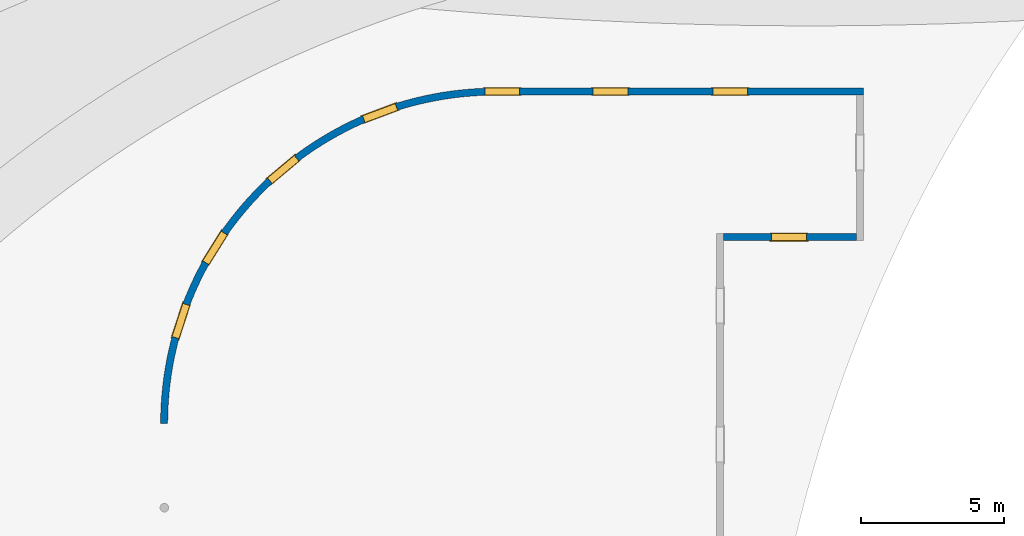
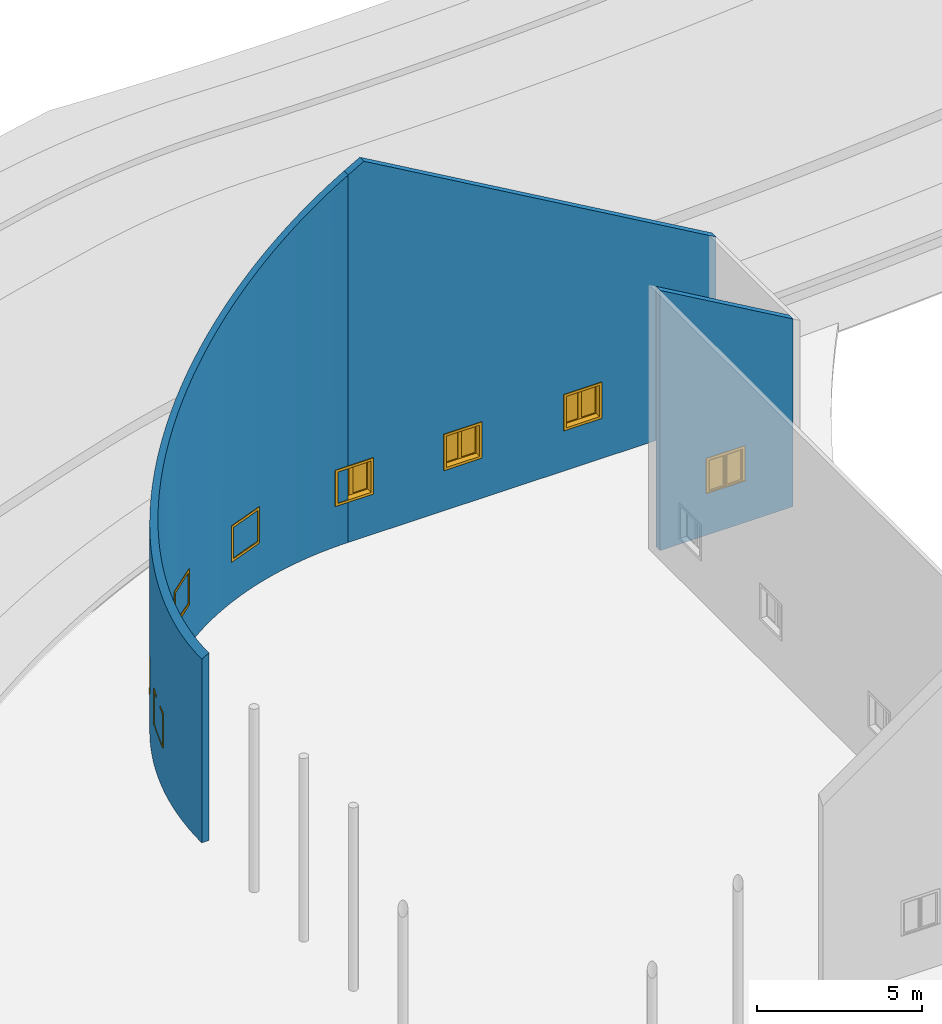
# One storey, part 10 of 39: 8 windows, 3 walls, 8 openings.
"""IFC2X3 building model written with IfcOpenShell, lengths in millimetres."""

from ifc_helpers import new_model, entity, si_unit, converted_unit, derived_unit, direction, frame, frame_2d, origin, origin_2d_with_axis, place, context, subcontext, project, spatial, polyline, circle_curve, parameter, trimmed, segment, composite_curve, rectangle, outline, extrude, clip, bounded_halfspace, source, transform, mapped, material, material_list, layer, layer_set, layer_usage, type_object, type_shapes, element, fill, save


model = new_model("IFC2X3")

# Units and contexts
model_context = context("Model", 3, precision=1e-06, world=origin(), true_north=direction((2.0, 6.12303176911189e-17, 1.0)))
context_of_model = context(None, 3, precision=1e-06, world=origin(), true_north=direction((2.0, 6.12303176911189e-17, 1.0)))
body_context = subcontext(model_context, "Body", "Model", "MODEL_VIEW")
ifc_project = project(units=[si_unit("LENGTHUNIT", "METRE", prefix="MILLI"), si_unit("AREAUNIT", "SQUARE_METRE", prefix="MILLI"), si_unit("VOLUMEUNIT", "CUBIC_METRE", prefix="MILLI"), converted_unit("PLANEANGLEUNIT", "DEGREE", entity("IfcRatioMeasure", 0.0174532925199433), si_unit("PLANEANGLEUNIT", "RADIAN"), dimensions=[0, 0, 0, 0, 0, 0, 0]), si_unit("MASSUNIT", "GRAM", prefix="KILO"), si_unit("TIMEUNIT", "SECOND"), si_unit("THERMODYNAMICTEMPERATUREUNIT", "KELVIN"), derived_unit("THERMALTRANSMITTANCEUNIT", [(si_unit("MASSUNIT", "GRAM", prefix="KILO"), 1), (si_unit("THERMODYNAMICTEMPERATUREUNIT", "KELVIN"), -1), (si_unit("TIMEUNIT", "SECOND"), -3)]), derived_unit("VOLUMETRICFLOWRATEUNIT", [(si_unit("LENGTHUNIT", "METRE"), 3), (si_unit("TIMEUNIT", "SECOND"), -1)])], contexts=[model_context, context_of_model])

# Site, building, storey
site_placement = place(None, origin())
site = spatial("IfcSite", under=ifc_project, at=site_placement, CompositionType="ELEMENT")
building_placement = place(site_placement, origin())
building = spatial("IfcBuilding", under=site, at=building_placement, CompositionType="ELEMENT")
storey_placement = place(building_placement, frame((0.0, 0.0, 4000.0)))
storey = spatial("IfcBuildingStorey", under=building, at=storey_placement, Name="Level 2", CompositionType="ELEMENT", Elevation=4000.0)

# Wall, openings, windows
ifc_material_1 = material(Name="Concrete - Cast In Situ")
ifc_layer = layer(ifc_material_1, 250.0)
ifc_layer_set = layer_set([ifc_layer], Name="Basic Wall:Structure wall")
ifc_layer_usage_1 = layer_usage(ifc_layer_set, "AXIS2", "NEGATIVE", 125.0)
wall_type = type_object("IfcWallType", Name="Basic Wall:Structure wall", PredefinedType="STANDARD", material=ifc_layer_set)
wall_1_placement = place(storey_placement, frame((-312721.196209224, 252902.530060918, 362.0), z_axis=(0.0, 0.0, 1.0), x_axis=(-1.0, 0.0, 0.0)))
wall_1 = element("IfcWallStandardCase", 1, at=wall_1_placement, inside=storey, type_object=wall_type, material=ifc_layer_usage_1, Name="Basic Wall:Structure wall", ObjectType="Basic Wall:Structure wall", context=body_context, shape_type="Clipping", body=[
    clip(clip(extrude(rectangle(XDim=12850.0000000001, YDim=249.999999999978, at=frame_2d((6425.00000000005, -3.33955085807247e-13), x_axis=(-1.0, 0.0))), origin(), (0.0, 0.0, 1.0), 13883.745878329), bounded_halfspace(frame((0.0, 125.0, 6782.33756729738), z_axis=(-0.499999999999959, 0.0, 0.866025403784462), x_axis=(0.0, -1.0, 0.0)), False, frame((0.0, 125.0, 6782.33756729738)), polyline([(0.0, 0.0), (0.0, -250.0), (12300.0, -250.0), (12300.0, 0.0), (250.0, 0.0), (0.0, 0.0)]))), bounded_halfspace(frame((12850.0, -125.0, 13566.2032302747), z_axis=(0.499999999999959, 0.0, 0.866025403784462), x_axis=(0.0, 1.0, 0.0)), False, frame((12850.0, -125.0, 13566.2032302747)), polyline([(0.0, 0.0), (0.0, 250.0), (-550.0, 250.0), (-550.0, 0.0), (0.0, 0.0)]))),
])
opening_1_placement = place(wall_1_placement, frame((13250.0, 125.0, 1553.0)))
opening_1 = element("IfcOpeningElement", 2, at=opening_1_placement, cuts=wall_1, Name="M_Casement Dbl with Trim:1220 x 1220mm:1220 x 1220mm:1", ObjectType="Opening", context=body_context, shape_type="SweptSolid", body=[
    extrude(rectangle(XDim=1220.0, YDim=1220.0, at=frame_2d((610.0, 610.0), x_axis=(-1.0, 0.0))), frame((0.0, 0.0, 0.0), z_axis=(0.0, -1.0, 0.0), x_axis=(0.0, 0.0, 1.0)), (0.0, 0.0, 1.0), 250.0),
])
opening_2_placement = place(wall_1_placement, frame((9460.05000000016, 125.0, 1553.0)))
opening_2 = element("IfcOpeningElement", 3, at=opening_2_placement, cuts=wall_1, Name="M_Casement Dbl with Trim:1220 x 1220mm:1220 x 1220mm:1", ObjectType="Opening", context=body_context, shape_type="SweptSolid", body=[
    extrude(rectangle(XDim=1220.0, YDim=1220.0, at=frame_2d((610.0, 610.0), x_axis=(-1.0, 0.0))), frame((0.0, 0.0, 0.0), z_axis=(0.0, -1.0, 0.0), x_axis=(0.0, 0.0, 1.0)), (0.0, 0.0, 1.0), 250.0),
])
opening_3_placement = place(wall_1_placement, frame((5270.1000000002, 125.0, 1553.0)))
opening_3 = element("IfcOpeningElement", 4, at=opening_3_placement, cuts=wall_1, Name="M_Casement Dbl with Trim:1220 x 1220mm:1220 x 1220mm:1", ObjectType="Opening", context=body_context, shape_type="SweptSolid", body=[
    extrude(rectangle(XDim=1220.0, YDim=1220.0, at=frame_2d((610.0, 610.0), x_axis=(-1.0, 0.0))), frame((0.0, 0.0, 0.0), z_axis=(0.0, -1.0, 0.0), x_axis=(0.0, 0.0, 1.0)), (0.0, 0.0, 1.0), 250.0),
])
ifc_material_2 = material(Name="Glass")
ifc_material_3 = material(Name="Sash")
ifc_material_4 = material(Name="Trim")
ifc_material_list_1 = material_list([ifc_material_2, ifc_material_3, ifc_material_4])
ifc_material_list_2 = material_list([ifc_material_2, ifc_material_3, ifc_material_4])
window_style_1 = type_object("IfcWindowStyle", Name="1220 x 1220mm", ConstructionType="NOTDEFINED", OperationType="NOTDEFINED", ParameterTakesPrecedence=False, Sizeable=False, material=ifc_material_list_2)
shared_shape_1 = source(origin(), body_context, "Body", "SweptSolid", [
    extrude(rectangle(XDim=482.999999999998, YDim=12.7, at=frame_2d((0.0, -1.68753899743024e-14), x_axis=(1.0, 0.0))), frame((305.0, 246.875, 63.5000000000002), z_axis=(0.0, 0.0, 1.0), x_axis=(-1.0, 0.0, 0.0)), (0.0, 0.0, 1.0), 1093.0),
    extrude(outline(polyline([(-285.949999999999, -590.950000000002), (285.949999999999, -590.950000000002), (285.949999999999, 590.950000000003), (-285.949999999999, 590.950000000003), (-285.949999999999, -590.950000000002)]), holes=[polyline([(-241.499999999998, -546.500000000003), (-241.499999999998, 546.500000000002), (241.5, 546.500000000002), (241.5, -546.500000000003), (-241.499999999998, -546.500000000003)])]), frame((305.0, 269.1, 610.0), z_axis=(0.0, -1.0, 0.0), x_axis=(-1.0, 0.0, 0.0)), (0.0, 0.0, 1.0), 44.45),
    extrude(rectangle(XDim=1359.89999999999, YDim=25.7, at=frame_2d((0.0, -1.68753899743024e-14), x_axis=(1.0, 0.0))), frame((610.0, 300.95, 0.0), z_axis=(0.0, 0.0, 1.0), x_axis=(-1.0, 0.0, 0.0)), (0.0, 0.0, 1.0), 19.0500000000014),
    extrude(outline(polyline([(-568.700000000007, 590.949999999995), (613.200000000007, 590.949999999995), (613.200000000007, 679.949999999994), (-657.700000000005, 679.949999999994), (-657.700000000005, -679.949999999993), (613.200000000006, -679.949999999993), (613.200000000006, -590.949999999995), (-568.700000000007, -590.949999999995), (-568.700000000007, 590.949999999995)])), frame((610.0, 301.1, 632.250000000007), z_axis=(0.0, -1.0, 0.0), x_axis=(0.0, 0.0, -1.0)), (0.0, 0.0, 1.0), 13.0),
    extrude(outline(polyline([(-667.25000000001, -667.249999999998), (667.25000000001, -667.249999999998), (667.25000000001, 667.249999999998), (-667.25000000001, 667.249999999998), (-667.25000000001, -667.249999999998)]), holes=[polyline([(-578.250000000011, -578.250000000001), (-578.250000000011, 578.249999999997), (578.24999999999, 578.249999999997), (578.24999999999, -578.250000000001), (-578.250000000011, -578.250000000001)])]), frame((610.0, 38.1, 610.0), z_axis=(0.0, -1.0, 0.0), x_axis=(0.0, 0.0, -1.0)), (0.0, 0.0, 1.0), 19.0),
    extrude(rectangle(XDim=482.999999999998, YDim=12.7, at=frame_2d((4.2632564145606e-14, 0.0), x_axis=(1.0, 0.0))), frame((915.0, 246.875, 63.4999999999994)), (0.0, 0.0, 1.0), 1093.0),
    extrude(outline(polyline([(-285.949999999999, -590.950000000002), (285.949999999999, -590.950000000002), (285.949999999999, 590.950000000002), (-285.949999999999, 590.950000000002), (-285.949999999999, -590.950000000002)]), holes=[polyline([(-241.499999999999, -546.500000000003), (-241.499999999999, 546.500000000001), (241.499999999999, 546.500000000001), (241.499999999999, -546.500000000003), (-241.499999999999, -546.500000000003)])]), frame((915.0, 269.1, 610.0), z_axis=(0.0, -1.0, 0.0), x_axis=(-1.0, 0.0, 0.0)), (0.0, 0.0, 1.0), 44.45),
    extrude(outline(polyline([(-610.0, -610.0), (610.0, -610.0), (610.0, 610.0), (-610.0, 610.0), (-610.0, -610.0)]), holes=[polyline([(-578.25, -578.250000000001), (-578.25, 578.25), (578.249999999997, 578.25), (578.249999999997, -578.250000000001), (-578.25, -578.250000000001)])]), frame((610.0, 224.65, 610.0), z_axis=(0.0, -1.0, 0.0), x_axis=(-1.0, 0.0, 0.0)), (0.0, 0.0, 1.0), 186.55),
    extrude(outline(polyline([(-610.0, -610.0), (610.0, -610.0), (610.0, 610.0), (-610.0, 610.0), (-610.0, -610.0)]), holes=[polyline([(-590.950000000002, -590.949999999996), (-590.950000000002, 590.95), (590.950000000003, 590.95), (590.950000000003, -590.949999999996), (-590.950000000002, -590.949999999996)])]), frame((610.0, 288.1, 610.0), z_axis=(0.0, -1.0, 0.0), x_axis=(0.0, 0.0, -1.0)), (0.0, 0.0, 1.0), 63.45),
    extrude(rectangle(XDim=38.0999999999998, YDim=63.5, at=frame_2d((0.0, -8.88178419700125e-15), x_axis=(1.0, 0.0))), frame((610.0, 256.4, 19.0499999999995)), (0.0, 0.0, 1.0), 1181.90000000001),
])
type_shapes(window_style_1, [shared_shape_1])
window_1_placement = place(opening_1_placement, frame((0.0, 38.0999999999476, 0.0), z_axis=(0.0, 0.0, 1.0), x_axis=(-1.0, 0.0, 0.0)))
window_1 = element("IfcWindow", 5, at=window_1_placement, inside=storey, type_object=window_style_1, material=ifc_material_list_1, Name="M_Casement Dbl with Trim:1220 x 1220mm", ObjectType="1220 x 1220mm", OverallHeight=1220.0, OverallWidth=1220.0, context=body_context, shape_type="MappedRepresentation", body=[
    mapped(shared_shape_1, transform((0.0, 0.0, 0.0), scale=1.0)),
])
fill(opening_1, window_1)
ifc_material_list_3 = material_list([ifc_material_2, ifc_material_3, ifc_material_4])
window_2_placement = place(opening_2_placement, frame((0.0, 38.0999999999476, 0.0), z_axis=(0.0, 0.0, 1.0), x_axis=(-1.0, 0.0, 0.0)))
window_2 = element("IfcWindow", 6, at=window_2_placement, inside=storey, type_object=window_style_1, material=ifc_material_list_3, Name="M_Casement Dbl with Trim:1220 x 1220mm", ObjectType="1220 x 1220mm", OverallHeight=1220.0, OverallWidth=1220.0, context=body_context, shape_type="MappedRepresentation", body=[
    mapped(shared_shape_1, transform((0.0, 0.0, 0.0), scale=1.0)),
])
fill(opening_2, window_2)
ifc_material_list_4 = material_list([ifc_material_2, ifc_material_3, ifc_material_4])
window_3_placement = place(opening_3_placement, frame((0.0, 38.0999999999767, 0.0), z_axis=(0.0, 0.0, 1.0), x_axis=(-1.0, 0.0, 0.0)))
window_3 = element("IfcWindow", 7, at=window_3_placement, inside=storey, type_object=window_style_1, material=ifc_material_list_4, Name="M_Casement Dbl with Trim:1220 x 1220mm", ObjectType="1220 x 1220mm", OverallHeight=1220.0, OverallWidth=1220.0, context=body_context, shape_type="MappedRepresentation", body=[
    mapped(shared_shape_1, transform((0.0, 0.0, 0.0), scale=1.0)),
])
fill(opening_3, window_3)

ifc_layer_usage_2 = layer_usage(ifc_layer_set, "AXIS2", "NEGATIVE", 125.0)
wall_2_placement = place(storey_placement, frame((-325571.196209225, 252902.530060918, 362.0)))
wall_2 = element("IfcWallStandardCase", 8, at=wall_2_placement, inside=storey, type_object=wall_type, material=ifc_layer_usage_2, Name="Basic Wall:Structure wall", ObjectType="Basic Wall:Structure wall", context=body_context, shape_type="Clipping", body=[
    clip(extrude(outline(composite_curve([segment(trimmed(circle_curve(frame_2d((0.0, -11625.0), x_axis=(1.0, 0.0)), 11500.0), [parameter(90.0000000000001)], [parameter(180.0)], True, "PARAMETER"), False, "CONTINUOUS"), segment(polyline([(0.0, -125.0), (0.0, 125.0)]), True, "CONTINUOUS"), segment(trimmed(circle_curve(frame_2d((0.0, -11625.0), x_axis=(1.0, 0.0)), 11750.0), [parameter(90.0000000000001)], [parameter(180.0)], True, "PARAMETER"), True, "CONTINUOUS"), segment(polyline([(-11750.0, -11625.0), (-11500.0, -11625.0)]), True, "CONTINUOUS")], self_intersect=False)), origin(), (0.0, 0.0, 1.0), 13566.2032302747), bounded_halfspace(frame((-11500.0, -11625.0, 6926.67513459476), z_axis=(-0.499999999999959, 0.0, 0.866025403784462), x_axis=(0.0, -1.0, 0.0)), False, frame((-11500.0, -11625.0, 6926.67513459476)), composite_curve([segment(trimmed(circle_curve(frame_2d((11500.0, 0.0), x_axis=(0.0, 1.0)), 11500.0), [parameter(4.07110999227331e-13)], [parameter(90.0000000000003)], True, "PARAMETER"), False, "CONTINUOUS"), segment(polyline([(11500.0, 11500.0), (11500.0, 11750.0)]), True, "CONTINUOUS"), segment(trimmed(circle_curve(frame_2d((11500.0, 0.0), x_axis=(0.0, -1.0)), 11750.0), [parameter(180.0)], [parameter(270.0)], True, "PARAMETER"), True, "CONTINUOUS"), segment(polyline([(-250.0, 0.0), (0.0, 0.0)]), True, "CONTINUOUS")], self_intersect=False))),
])
opening_4_placement = place(wall_2_placement, frame((-10856.0480152831, -8732.77158017401, 1553.0)))
opening_4 = element("IfcOpeningElement", 9, at=opening_4_placement, cuts=wall_2, Name="M_Casement Dbl with Trim:1220 x 1220mm:1220 x 1220mm:1", ObjectType="Opening", context=body_context, shape_type="SweptSolid", body=[
    extrude(rectangle(XDim=1220.0, YDim=1220.0, at=frame_2d((610.0, 610.0), x_axis=(-1.0, 0.0))), frame((0.0, 0.0, 0.0), z_axis=(-0.950891951006564, 0.309523016124699, 0.0), x_axis=(0.0, 0.0, 1.0)), (0.0, 0.0, 1.0), 266.687395378803),
])
opening_5_placement = place(wall_2_placement, frame((-9835.49466339912, -6195.28467884089, 1553.0)))
opening_5 = element("IfcOpeningElement", 10, at=opening_5_placement, cuts=wall_2, Name="M_Casement Dbl with Trim:1220 x 1220mm:1220 x 1220mm:1", ObjectType="Opening", context=body_context, shape_type="SweptSolid", body=[
    extrude(rectangle(XDim=1220.0, YDim=1220.0, at=frame_2d((610.0, 610.0), x_axis=(-1.0, 0.0))), frame((0.0, 0.0, 0.0), z_axis=(-0.84792328815928, 0.530118946461221, 0.0), x_axis=(0.0, 0.0, 1.0)), (0.0, 0.0, 1.0), 266.687395378802),
])
opening_6_placement = place(wall_2_placement, frame((-7673.32828391717, -3418.97801673563, 1553.0)))
opening_6 = element("IfcOpeningElement", 11, at=opening_6_placement, cuts=wall_2, Name="M_Casement Dbl with Trim:1220 x 1220mm:1220 x 1220mm:1", ObjectType="Opening", context=body_context, shape_type="SweptSolid", body=[
    extrude(rectangle(XDim=1220.0, YDim=1220.0, at=frame_2d((610.0, 610.0), x_axis=(-1.0, 0.0))), frame((0.0, 0.0, 0.0), z_axis=(-0.64233553467591, 0.766423551890606, 0.0), x_axis=(0.0, 0.0, 1.0)), (0.0, 0.0, 1.0), 266.687395378802),
])
opening_7_placement = place(wall_2_placement, frame((-4500.67179938865, -1331.18063609193, 1553.0)))
opening_7 = element("IfcOpeningElement", 12, at=opening_7_placement, cuts=wall_2, Name="M_Casement Dbl with Trim:1220 x 1220mm:1220 x 1220mm:1", ObjectType="Opening", context=body_context, shape_type="SweptSolid", body=[
    extrude(rectangle(XDim=1220.0, YDim=1220.0, at=frame_2d((610.0, 610.0), x_axis=(-1.0, 0.0))), frame((0.0, 0.0, 0.0), z_axis=(-0.350264373953015, 0.936650878577126, 0.0), x_axis=(0.0, 0.0, 1.0)), (0.0, 0.0, 1.0), 266.687395378802),
])
ifc_material_list_5 = material_list([ifc_material_2, ifc_material_3, ifc_material_4])
ifc_material_list_6 = material_list([ifc_material_2, ifc_material_3, ifc_material_4])
window_style_2 = type_object("IfcWindowStyle", Name="1220 x 1220mm", ConstructionType="NOTDEFINED", OperationType="NOTDEFINED", ParameterTakesPrecedence=False, Sizeable=False, material=ifc_material_list_6)
shared_shape_2 = source(origin(), body_context, "Body", "SweptSolid", [
    extrude(rectangle(XDim=12.7, YDim=482.999999999998, at=origin_2d_with_axis()), frame((915.0, 208.775, 63.5000000000002), z_axis=(0.0, 0.0, 1.0), x_axis=(0.0, -1.0, 0.0)), (0.0, 0.0, 1.0), 1093.0),
    extrude(outline(polyline([(-285.949999999999, -590.950000000002), (285.949999999999, -590.950000000002), (285.949999999999, 590.950000000003), (-285.949999999999, 590.950000000003), (-285.949999999999, -590.950000000002)]), holes=[polyline([(-241.499999999998, -546.500000000003), (-241.499999999998, 546.500000000002), (241.5, 546.500000000002), (241.5, -546.500000000003), (-241.499999999998, -546.500000000003)])]), frame((915.0, 186.55, 610.0), z_axis=(0.0, 1.0, 0.0), x_axis=(1.0, 0.0, 0.0)), (0.0, 0.0, 1.0), 44.45),
    extrude(rectangle(XDim=25.7, YDim=1359.89999999999, at=frame_2d((-1.68753899743024e-14, 0.0), x_axis=(1.0, 0.0))), frame((610.0, 262.85, 0.0), z_axis=(0.0, 0.0, 1.0), x_axis=(0.0, -1.0, 0.0)), (0.0, 0.0, 1.0), 19.0500000000014),
    extrude(outline(polyline([(-568.700000000007, 590.949999999995), (613.200000000007, 590.949999999995), (613.200000000007, 679.949999999994), (-657.700000000005, 679.949999999994), (-657.700000000005, -679.949999999993), (613.200000000006, -679.949999999993), (613.200000000006, -590.949999999995), (-568.700000000007, -590.949999999995), (-568.700000000007, 590.949999999995)])), frame((610.0, 250.0, 632.250000000007), z_axis=(0.0, 1.0, 0.0), x_axis=(0.0, 0.0, -1.0)), (0.0, 0.0, 1.0), 13.0),
    extrude(outline(polyline([(-667.25000000001, -667.249999999998), (667.25000000001, -667.249999999998), (667.25000000001, 667.249999999998), (-667.25000000001, 667.249999999998), (-667.25000000001, -667.249999999998)]), holes=[polyline([(-578.250000000011, -578.250000000001), (-578.250000000011, 578.249999999997), (578.24999999999, 578.249999999997), (578.24999999999, -578.250000000001), (-578.250000000011, -578.250000000001)])]), frame((610.0, -19.0, 610.0), z_axis=(0.0, 1.0, 0.0), x_axis=(0.0, 0.0, -1.0)), (0.0, 0.0, 1.0), 19.0),
    extrude(rectangle(XDim=12.7, YDim=482.999999999998, at=frame_2d((1.68753899743024e-14, 4.2632564145606e-14), x_axis=(1.0, 0.0))), frame((305.0, 208.775, 63.4999999999994), z_axis=(0.0, 0.0, 1.0), x_axis=(0.0, 1.0, 0.0)), (0.0, 0.0, 1.0), 1093.0),
    extrude(outline(polyline([(-285.949999999999, -590.950000000002), (285.949999999999, -590.950000000002), (285.949999999999, 590.950000000002), (-285.949999999999, 590.950000000002), (-285.949999999999, -590.950000000002)]), holes=[polyline([(-241.499999999999, -546.500000000003), (-241.499999999999, 546.500000000001), (241.499999999999, 546.500000000001), (241.499999999999, -546.500000000003), (-241.499999999999, -546.500000000003)])]), frame((305.0, 186.55, 610.0), z_axis=(0.0, 1.0, 0.0), x_axis=(1.0, 0.0, 0.0)), (0.0, 0.0, 1.0), 44.45),
    extrude(outline(polyline([(-610.0, -610.0), (610.0, -610.0), (610.0, 610.0), (-610.0, 610.0), (-610.0, -610.0)]), holes=[polyline([(-578.25, -578.250000000001), (-578.25, 578.25), (578.249999999997, 578.25), (578.249999999997, -578.250000000001), (-578.25, -578.250000000001)])]), frame((610.0, 0.0, 610.0), z_axis=(0.0, 1.0, 0.0), x_axis=(1.0, 0.0, 0.0)), (0.0, 0.0, 1.0), 186.55),
    extrude(outline(polyline([(-610.0, -610.0), (610.0, -610.0), (610.0, 610.0), (-610.0, 610.0), (-610.0, -610.0)]), holes=[polyline([(-590.950000000002, -590.949999999996), (-590.950000000002, 590.95), (590.950000000003, 590.95), (590.950000000003, -590.949999999996), (-590.950000000002, -590.949999999996)])]), frame((610.0, 186.55, 610.0), z_axis=(0.0, 1.0, 0.0), x_axis=(0.0, 0.0, -1.0)), (0.0, 0.0, 1.0), 63.45),
    extrude(rectangle(XDim=63.5, YDim=38.0999999999998, at=frame_2d((-8.88178419700125e-15, 0.0), x_axis=(1.0, 0.0))), frame((610.0, 218.3, 19.0499999999995), z_axis=(0.0, 0.0, 1.0), x_axis=(0.0, 1.0, 0.0)), (0.0, 0.0, 1.0), 1181.90000000001),
])
type_shapes(window_style_2, [shared_shape_2])
window_4_placement = place(opening_4_placement, frame((-252.951838938403, 82.3378681874892, 0.0), z_axis=(0.0, 0.0, 1.0), x_axis=(0.309523016124699, 0.950891951006564, 0.0)))
window_4 = element("IfcWindow", 13, at=window_4_placement, inside=storey, type_object=window_style_2, material=ifc_material_list_5, Name="M_Casement Dbl with Trim:1220 x 1220mm", ObjectType="1220 x 1220mm", OverallHeight=1220.0, OverallWidth=1220.00000000003, context=body_context, shape_type="MappedRepresentation", body=[
    mapped(shared_shape_2, transform((0.0, 0.0, 0.0), scale=1.0)),
])
fill(opening_4, window_4)
ifc_material_list_7 = material_list([ifc_material_2, ifc_material_3, ifc_material_4])
window_5_placement = place(opening_5_placement, frame((-225.560595808551, 141.019768041471, 0.0), z_axis=(0.0, 0.0, 1.0), x_axis=(0.530118946461221, 0.84792328815928, 0.0)))
window_5 = element("IfcWindow", 14, at=window_5_placement, inside=storey, type_object=window_style_2, material=ifc_material_list_7, Name="M_Casement Dbl with Trim:1220 x 1220mm", ObjectType="1220 x 1220mm", OverallHeight=1220.0, OverallWidth=1220.0, context=body_context, shape_type="MappedRepresentation", body=[
    mapped(shared_shape_2, transform((0.0, 0.0, 0.0), scale=1.0)),
])
fill(opening_5, window_5)
ifc_material_list_8 = material_list([ifc_material_2, ifc_material_3, ifc_material_4])
window_6_placement = place(opening_6_placement, frame((-170.871101116994, 203.880416330416, 0.0), z_axis=(0.0, 0.0, 1.0), x_axis=(0.766423551890606, 0.64233553467591, 0.0)))
window_6 = element("IfcWindow", 15, at=window_6_placement, inside=storey, type_object=window_style_2, material=ifc_material_list_8, Name="M_Casement Dbl with Trim:1220 x 1220mm", ObjectType="1220 x 1220mm", OverallHeight=1220.0, OverallWidth=1220.00000000001, context=body_context, shape_type="MappedRepresentation", body=[
    mapped(shared_shape_2, transform((0.0, 0.0, 0.0), scale=1.0)),
])
fill(opening_6, window_6)
ifc_material_list_9 = material_list([ifc_material_2, ifc_material_3, ifc_material_4])
window_7_placement = place(opening_7_placement, frame((-93.1756940546911, 249.163495314657, 0.0), z_axis=(0.0, 0.0, 1.0), x_axis=(0.936650878577126, 0.350264373953015, 0.0)))
window_7 = element("IfcWindow", 16, at=window_7_placement, inside=storey, type_object=window_style_2, material=ifc_material_list_9, Name="M_Casement Dbl with Trim:1220 x 1220mm", ObjectType="1220 x 1220mm", OverallHeight=1220.0, OverallWidth=1220.00000000001, context=body_context, shape_type="MappedRepresentation", body=[
    mapped(shared_shape_2, transform((0.0, 0.0, 0.0), scale=1.0)),
])
fill(opening_7, window_7)

# Wall, opening, window
ifc_layer_usage_3 = layer_usage(ifc_layer_set, "AXIS2", "NEGATIVE", 125.0)
wall_3_placement = place(storey_placement, frame((-317617.211895131, 247814.404995702, 362.0)))
wall_3 = element("IfcWallStandardCase", 17, at=wall_3_placement, inside=storey, type_object=wall_type, material=ifc_layer_usage_3, Name="Basic Wall:Structure wall", ObjectType="Basic Wall:Structure wall", context=body_context, shape_type="Clipping", body=[
    clip(extrude(rectangle(XDim=4646.0156859063, YDim=249.999999999978, at=frame_2d((2323.00784295315, 0.0), x_axis=(-1.0, 0.0))), origin(), (0.0, 0.0, 1.0), 9609.05354151169), bounded_halfspace(frame((0.0, -125.0, 9609.05354151169), z_axis=(0.499999999999959, 0.0, 0.866025403784462), x_axis=(0.0, 1.0, 0.0)), False, frame((0.0, -125.0, 9609.05354151169)), polyline([(0.0, 0.0), (4646.0156859063, 0.0), (4646.0156859063, 250.0), (0.0, 250.0), (0.0, 0.0)]))),
])
opening_8_placement = place(wall_3_placement, frame((2898.03284295322, 125.0, 1553.0)))
opening_8 = element("IfcOpeningElement", 18, at=opening_8_placement, cuts=wall_3, Name="M_Casement Dbl with Trim:1220 x 1220mm:1220 x 1220mm:1", ObjectType="Opening", context=body_context, shape_type="SweptSolid", body=[
    extrude(rectangle(XDim=1220.0, YDim=1220.0, at=frame_2d((610.0, 610.0), x_axis=(-1.0, 0.0))), frame((0.0, 0.0, 0.0), z_axis=(0.0, -1.0, 0.0), x_axis=(0.0, 0.0, 1.0)), (0.0, 0.0, 1.0), 250.0),
])
ifc_material_list_10 = material_list([ifc_material_2, ifc_material_3, ifc_material_4])
ifc_material_list_11 = material_list([ifc_material_2, ifc_material_3, ifc_material_4])
window_style_3 = type_object("IfcWindowStyle", Name="1220 x 1220mm", ConstructionType="NOTDEFINED", OperationType="NOTDEFINED", ParameterTakesPrecedence=False, Sizeable=False, material=ifc_material_list_11)
shared_shape_3 = source(origin(), body_context, "Body", "SweptSolid", [
    extrude(rectangle(XDim=12.7, YDim=482.999999999998, at=origin_2d_with_axis()), frame((915.0, 208.775, 63.5000000000002), z_axis=(0.0, 0.0, 1.0), x_axis=(0.0, -1.0, 0.0)), (0.0, 0.0, 1.0), 1093.0),
    extrude(outline(polyline([(-285.949999999999, -590.950000000002), (285.949999999999, -590.950000000002), (285.949999999999, 590.950000000003), (-285.949999999999, 590.950000000003), (-285.949999999999, -590.950000000002)]), holes=[polyline([(-241.499999999998, -546.500000000003), (-241.499999999998, 546.500000000002), (241.5, 546.500000000002), (241.5, -546.500000000003), (-241.499999999998, -546.500000000003)])]), frame((915.0, 186.55, 610.0), z_axis=(0.0, 1.0, 0.0), x_axis=(1.0, 0.0, 0.0)), (0.0, 0.0, 1.0), 44.45),
    extrude(rectangle(XDim=25.7, YDim=1359.89999999999, at=frame_2d((-1.68753899743024e-14, 0.0), x_axis=(1.0, 0.0))), frame((610.0, 262.85, 0.0), z_axis=(0.0, 0.0, 1.0), x_axis=(0.0, -1.0, 0.0)), (0.0, 0.0, 1.0), 19.0500000000014),
    extrude(outline(polyline([(-568.700000000007, 590.949999999995), (613.200000000007, 590.949999999995), (613.200000000007, 679.949999999994), (-657.700000000005, 679.949999999994), (-657.700000000005, -679.949999999993), (613.200000000006, -679.949999999993), (613.200000000006, -590.949999999995), (-568.700000000007, -590.949999999995), (-568.700000000007, 590.949999999995)])), frame((610.0, 250.0, 632.250000000007), z_axis=(0.0, 1.0, 0.0), x_axis=(0.0, 0.0, -1.0)), (0.0, 0.0, 1.0), 13.0),
    extrude(outline(polyline([(-667.25000000001, -667.249999999998), (667.25000000001, -667.249999999998), (667.25000000001, 667.249999999998), (-667.25000000001, 667.249999999998), (-667.25000000001, -667.249999999998)]), holes=[polyline([(-578.250000000011, -578.250000000001), (-578.250000000011, 578.249999999997), (578.24999999999, 578.249999999997), (578.24999999999, -578.250000000001), (-578.250000000011, -578.250000000001)])]), frame((610.0, -19.0, 610.0), z_axis=(0.0, 1.0, 0.0), x_axis=(0.0, 0.0, -1.0)), (0.0, 0.0, 1.0), 19.0),
    extrude(rectangle(XDim=12.7, YDim=482.999999999998, at=frame_2d((1.68753899743024e-14, 4.2632564145606e-14), x_axis=(1.0, 0.0))), frame((305.0, 208.775, 63.4999999999994), z_axis=(0.0, 0.0, 1.0), x_axis=(0.0, 1.0, 0.0)), (0.0, 0.0, 1.0), 1093.0),
    extrude(outline(polyline([(-285.949999999999, -590.950000000002), (285.949999999999, -590.950000000002), (285.949999999999, 590.950000000002), (-285.949999999999, 590.950000000002), (-285.949999999999, -590.950000000002)]), holes=[polyline([(-241.499999999999, -546.500000000003), (-241.499999999999, 546.500000000001), (241.499999999999, 546.500000000001), (241.499999999999, -546.500000000003), (-241.499999999999, -546.500000000003)])]), frame((305.0, 186.55, 610.0), z_axis=(0.0, 1.0, 0.0), x_axis=(1.0, 0.0, 0.0)), (0.0, 0.0, 1.0), 44.45),
    extrude(outline(polyline([(-610.0, -610.0), (610.0, -610.0), (610.0, 610.0), (-610.0, 610.0), (-610.0, -610.0)]), holes=[polyline([(-578.25, -578.250000000001), (-578.25, 578.25), (578.249999999997, 578.25), (578.249999999997, -578.250000000001), (-578.25, -578.250000000001)])]), frame((610.0, 0.0, 610.0), z_axis=(0.0, 1.0, 0.0), x_axis=(1.0, 0.0, 0.0)), (0.0, 0.0, 1.0), 186.55),
    extrude(outline(polyline([(-610.0, -610.0), (610.0, -610.0), (610.0, 610.0), (-610.0, 610.0), (-610.0, -610.0)]), holes=[polyline([(-590.950000000002, -590.949999999996), (-590.950000000002, 590.95), (590.950000000003, 590.95), (590.950000000003, -590.949999999996), (-590.950000000002, -590.949999999996)])]), frame((610.0, 186.55, 610.0), z_axis=(0.0, 1.0, 0.0), x_axis=(0.0, 0.0, -1.0)), (0.0, 0.0, 1.0), 63.45),
    extrude(rectangle(XDim=63.5, YDim=38.0999999999998, at=frame_2d((-8.88178419700125e-15, 0.0), x_axis=(1.0, 0.0))), frame((610.0, 218.3, 19.0499999999995), z_axis=(0.0, 0.0, 1.0), x_axis=(0.0, 1.0, 0.0)), (0.0, 0.0, 1.0), 1181.90000000001),
])
type_shapes(window_style_3, [shared_shape_3])
window_8_placement = place(opening_8_placement, frame((0.0, 0.0, 0.0), z_axis=(0.0, 0.0, 1.0), x_axis=(-1.0, 0.0, 0.0)))
window_8 = element("IfcWindow", 19, at=window_8_placement, inside=storey, type_object=window_style_3, material=ifc_material_list_10, Name="M_Casement Dbl with Trim:1220 x 1220mm", ObjectType="1220 x 1220mm", OverallHeight=1220.0, OverallWidth=1220.0, context=body_context, shape_type="MappedRepresentation", body=[
    mapped(shared_shape_3, transform((0.0, 0.0, 0.0), scale=1.0)),
])
fill(opening_8, window_8)

save(model, "model.ifc")
